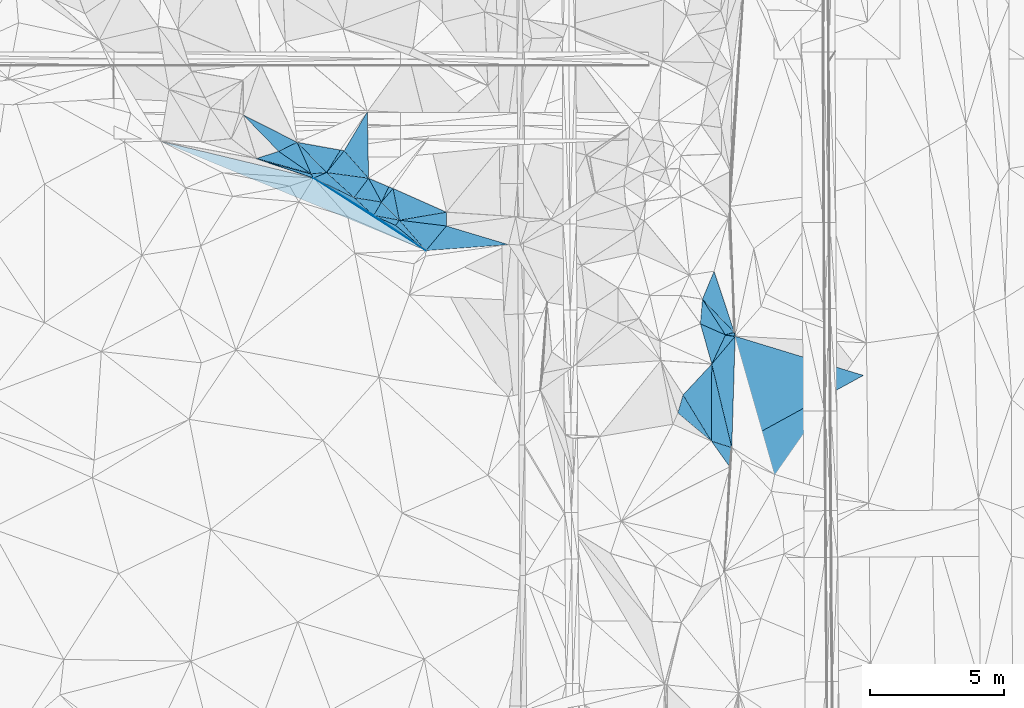
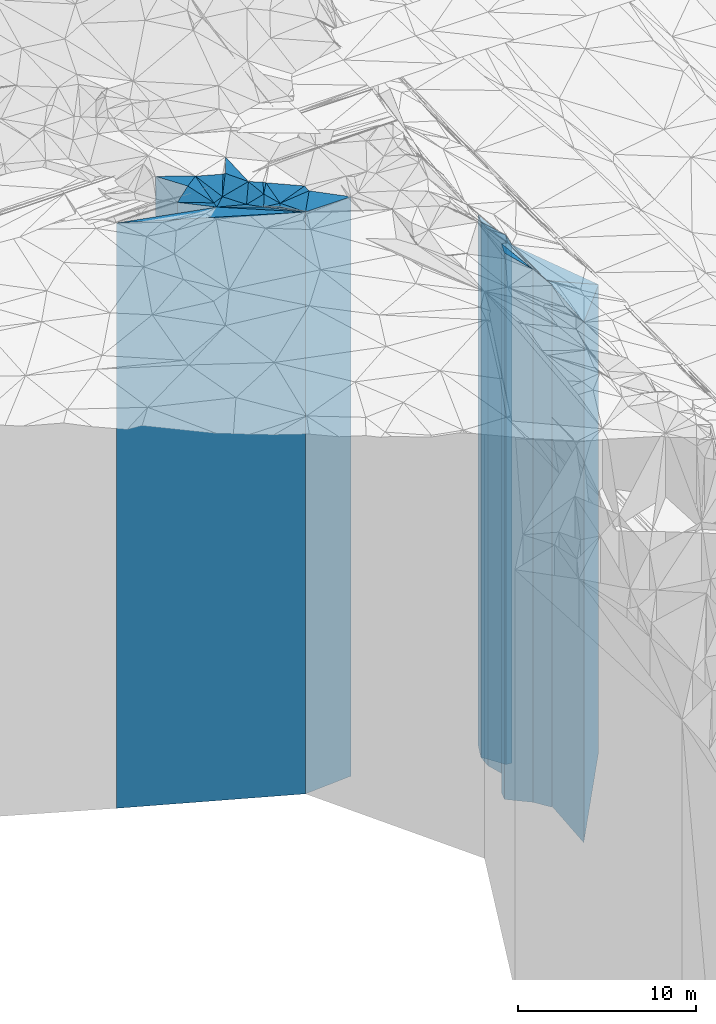
# One storey, part 208 of 275: 41 plates.
"""IFC2X3 building model written with IfcOpenShell, lengths in millimetres."""

from ifc_helpers import new_model, si_unit, frame, origin_with_axes, place, context, subcontext, project, spatial, faceted_brep, material, type_object, element, save


model = new_model("IFC2X3")

# Units and contexts
model_context = context("Model", 3, precision=1e-05, world=origin_with_axes())
body_context = subcontext(model_context, "Body", "Model", "MODEL_VIEW")
ifc_project = project(units=[si_unit("LENGTHUNIT", "METRE", prefix="MILLI"), si_unit("AREAUNIT", "SQUARE_METRE"), si_unit("VOLUMEUNIT", "CUBIC_METRE"), si_unit("MASSUNIT", "GRAM", prefix="KILO"), si_unit("TIMEUNIT", "SECOND"), si_unit("PLANEANGLEUNIT", "RADIAN"), si_unit("SOLIDANGLEUNIT", "STERADIAN"), si_unit("THERMODYNAMICTEMPERATUREUNIT", "DEGREE_CELSIUS"), si_unit("LUMINOUSINTENSITYUNIT", "LUMEN")], contexts=[model_context])

# Site, building, storey
site_placement = place(None, origin_with_axes())
site = spatial("IfcSite", under=ifc_project, at=site_placement, CompositionType="ELEMENT")
building_placement = place(site_placement, origin_with_axes())
building = spatial("IfcBuilding", under=site, at=building_placement, Name="Undefined", CompositionType="ELEMENT")
storey_placement = place(building_placement, origin_with_axes())
storey = spatial("IfcBuildingStorey", under=building, at=storey_placement, Name="Undefined", CompositionType="ELEMENT", Elevation=0.0)

# Plates
ifc_material = material()
plate_type_1 = type_object("IfcPlateType", PredefinedType="NOTDEFINED")
plate_1_placement = place(storey_placement, frame((-110294.740973737, 54065.2634649657, 27899.0), z_axis=(-0.804874960058612, 0.593444436043213, 0.0), x_axis=(0.593444436043218, 0.804874960058609, 0.0)))
element("IfcPlate", 1, at=plate_1_placement, inside=storey, type_object=plate_type_1, material=ifc_material, Name="00", context=body_context, shape_type="Brep", body=[
    faceted_brep([(-7.27595761418343e-12, -20071.0, 0.0), (-188.532791137703, -20151.0, 879.406250000015), (-188.532791137703, 20071.0, 879.406250000015), (-7.27595761418343e-12, 20071.0, 0.0), (241.867736816406, -20181.0, 1.16415321826935e-10), (241.867736816406, 20071.0, 1.16415321826935e-10)], [[[0, 1, 2, 3]], [[1, 4, 5, 2]], [[4, 0, 3, 5]], [[5, 3, 2]], [[4, 1, 0]]]),
])
plate_type_2 = type_object("IfcPlateType", PredefinedType="NOTDEFINED")
plate_2_placement = place(storey_placement, frame((-110294.740973737, 54065.2634649657, 27824.5), z_axis=(-0.411538900970538, -0.911392194934739, 0.0), x_axis=(-0.911392194934741, 0.411538900970533, 0.0)))
element("IfcPlate", 2, at=plate_2_placement, inside=storey, type_object=plate_type_2, material=ifc_material, Name="00", context=body_context, shape_type="Brep", body=[
    faceted_brep([(0.0, -20145.5, -1.59161572810262e-11), (-1425.35705566406, -19996.5, 394.501281738265), (-1425.35705566406, 19996.5, 394.501281738265), (0.0, 19996.5, -1.59161572810262e-11), (899.388671875, -20225.5, -2.32967067859136e-09), (899.388671875, 19996.5, -2.32967067859136e-09)], [[[0, 1, 2, 3]], [[1, 4, 5, 2]], [[4, 0, 3, 5]], [[5, 3, 2]], [[4, 1, 0]]]),
])
plate_type_3 = type_object("IfcPlateType", PredefinedType="NOTDEFINED")
plate_3_placement = place(storey_placement, frame((-110390.601709133, 55444.2887437077, 27954.0), z_axis=(0.762095998100835, -0.647464045085665, 0.0), x_axis=(-0.647464045085671, -0.76209599810083, 0.0)))
element("IfcPlate", 3, at=plate_3_placement, inside=storey, type_object=plate_type_3, material=ifc_material, Name="00", context=body_context, shape_type="Brep", body=[
    faceted_brep([(-7.27595761418343e-12, -20896.0, 0.0), (747.589721679695, -20126.0, 949.267883300781), (747.589721679695, 20126.0, 949.267883300781), (-7.27595761418343e-12, 20126.0, 0.0), (666.408264160164, -20576.0, 3.84170562028885e-09), (666.408264160164, 20126.0, 3.84170562028885e-09)], [[[0, 1, 2, 3]], [[1, 4, 5, 2]], [[4, 0, 3, 5]], [[5, 3, 2]], [[4, 1, 0]]]),
])
plate_type_4 = type_object("IfcPlateType", PredefinedType="NOTDEFINED")
plate_4_placement = place(storey_placement, frame((-110294.740973737, 54065.2634649657, 27824.5), z_axis=(0.639737251043329, 0.768593683052057, 0.0), x_axis=(0.768593683052057, -0.639737251043329, 0.0)))
element("IfcPlate", 4, at=plate_4_placement, inside=storey, type_object=plate_type_4, material=ifc_material, Name="00", context=body_context, shape_type="Brep", body=[
    faceted_brep([(0.0, -20145.5, -1.59161572810262e-11), (-14.2196102142334, -20255.5, 241.449386596683), (-14.2196102142334, 19996.5, 241.449386596683), (0.0, 19996.5, -1.59161572810262e-11), (1478.94348144533, -19996.5, 5.68616087548435e-09), (1478.94348144533, 19996.5, 5.68616087548435e-09)], [[[0, 1, 2, 3]], [[1, 4, 5, 2]], [[4, 0, 3, 5]], [[5, 3, 2]], [[4, 1, 0]]]),
])
plate_type_5 = type_object("IfcPlateType", PredefinedType="NOTDEFINED")
plate_5_placement = place(storey_placement, frame((-110822.07711198, 54936.4216580074, 27939.0), z_axis=(-0.162954212081307, -0.986633632492305, 0.0), x_axis=(-0.986633632492305, 0.162954212081309, 0.0)))
element("IfcPlate", 5, at=plate_5_placement, inside=storey, type_object=plate_type_5, material=ifc_material, Name="00", context=body_context, shape_type="Brep", body=[
    faceted_brep([(0.0, -20591.0, 0.0), (206.807800292969, -20111.0, 541.969116210938), (206.807800292969, 20111.0, 541.969116210938), (0.0, 20111.0, 0.0), (1040.09619140625, -20141.0, -8.29459168016911e-10), (1040.09619140625, 20111.0, -8.29459168016911e-10)], [[[0, 1, 2, 3]], [[1, 4, 5, 2]], [[4, 0, 3, 5]], [[5, 3, 2]], [[4, 1, 0]]]),
])
plate_type_6 = type_object("IfcPlateType", PredefinedType="NOTDEFINED")
plate_6_placement = place(storey_placement, frame((-111114.436798136, 54435.3968942372, 27906.0), z_axis=(-0.674538327096492, -0.7382398291056, 0.0), x_axis=(-0.738239829105603, 0.674538327096489, 0.0)))
element("IfcPlate", 6, at=plate_6_placement, inside=storey, type_object=plate_type_6, material=ifc_material, Name="00", context=body_context, shape_type="Brep", body=[
    faceted_brep([(2.91038304567337e-11, -20144.0, -1.45519152283669e-11), (2605.13696289063, -20078.0, 486.845397949219), (2605.13696289063, 20078.0, 486.845397949219), (2.91038304567337e-11, 20078.0, -1.45519152283669e-11), (994.032165527358, -20174.0, 9.60426405072212e-10), (994.032165527358, 20078.0, 9.60426405072212e-10)], [[[0, 1, 2, 3]], [[1, 4, 5, 2]], [[4, 0, 3, 5]], [[5, 3, 2]], [[4, 1, 0]]]),
])
plate_type_7 = type_object("IfcPlateType", PredefinedType="NOTDEFINED")
plate_7_placement = place(storey_placement, frame((-110151.205913781, 54259.9367465515, 27939.0), z_axis=(-0.710046754280329, -0.704154533278008, 0.0), x_axis=(-0.704154533278, 0.710046754280337, 0.0)))
element("IfcPlate", 7, at=plate_7_placement, inside=storey, type_object=plate_type_7, material=ifc_material, Name="00", context=body_context, shape_type="Brep", body=[
    faceted_brep([(0.0, -20141.0, -7.27595761418343e-12), (802.848327636719, -20111.0, 560.387878417961), (802.848327636719, 20111.0, 560.387878417961), (0.0, 20111.0, 0.0), (952.73291015625, -20591.0, -1.09139364212751e-09), (952.73291015625, 20111.0, -1.09139364212751e-09)], [[[0, 1, 2, 3]], [[1, 4, 5, 2]], [[4, 0, 3, 5]], [[5, 3, 2]], [[4, 1, 0]]]),
])
plate_type_8 = type_object("IfcPlateType", PredefinedType="NOTDEFINED")
plate_8_placement = place(storey_placement, frame((-112874.021187046, 56040.9693087682, 27906.0), z_axis=(0.388926703048877, -0.921268701115766, 0.0), x_axis=(-0.921268701115766, -0.388926703048877, 0.0)))
element("IfcPlate", 8, at=plate_8_placement, inside=storey, type_object=plate_type_8, material=ifc_material, Name="00", context=body_context, shape_type="Brep", body=[
    faceted_brep([(1.45519152283669e-11, -20494.0, -1.45519152283669e-11), (-581.321960449204, -20174.0, 1260.3828125), (-581.321960449204, 20078.0, 1260.3828125), (2.91038304567337e-11, 20078.0, -1.45519152283669e-11), (534.075866699233, -20078.0, 4.65661287307739e-10), (534.075866699233, 20078.0, 4.65661287307739e-10)], [[[0, 1, 2, 3]], [[1, 4, 5, 2]], [[4, 0, 3, 5]], [[5, 3, 2]], [[4, 1, 0]]]),
])
plate_type_9 = type_object("IfcPlateType", PredefinedType="NOTDEFINED")
plate_9_placement = place(storey_placement, frame((-110548.879326198, 55505.5112553854, 28179.0), z_axis=(-0.392684399118446, -0.919673291277389, 0.0), x_axis=(-0.91967329127739, 0.392684399118444, 0.0)))
element("IfcPlate", 9, at=plate_9_placement, inside=storey, type_object=plate_type_9, material=ifc_material, Name="00", context=body_context, shape_type="Brep", body=[
    faceted_brep([(-1.45519152283669e-11, -20731.0, -1.36424205265939e-11), (27.7800998687744, -20351.0, 630.656982421861), (27.7800998687744, 20351.0, 630.656982421861), (-1.45519152283669e-11, 20351.0, -1.36424205265939e-11), (820.731384277329, -20841.0, 1.99452188098803e-09), (820.731384277329, 20351.0, 1.99452188098803e-09)], [[[0, 1, 2, 3]], [[1, 4, 5, 2]], [[4, 0, 3, 5]], [[5, 3, 2]], [[4, 1, 0]]]),
])
plate_type_10 = type_object("IfcPlateType", PredefinedType="NOTDEFINED")
plate_10_placement = place(storey_placement, frame((-111303.684056734, 55827.7996646714, 27954.0), z_axis=(-0.134513978030471, -0.990911696224451, 0.0), x_axis=(-0.990911696224451, 0.134513978030468, 0.0)))
element("IfcPlate", 10, at=plate_10_placement, inside=storey, type_object=plate_type_10, material=ifc_material, Name="00", context=body_context, shape_type="Brep", body=[
    faceted_brep([(0.0, -21066.0, -7.27595761418343e-12), (442.533233642578, -20126.0, 788.58374023436), (442.533233642578, 20126.0, 788.58374023436), (-7.27595761418343e-12, 20126.0, 0.0), (1584.73974609375, -20446.0, 4.19822754338384e-09), (1584.73974609375, 20126.0, 4.19822754338384e-09)], [[[0, 1, 2, 3]], [[1, 4, 5, 2]], [[4, 0, 3, 5]], [[5, 3, 2]], [[4, 1, 0]]]),
])
plate_type_11 = type_object("IfcPlateType", PredefinedType="NOTDEFINED")
plate_11_placement = place(storey_placement, frame((-111351.75100567, 58310.4171479781, 28424.0), z_axis=(0.859259778895066, -0.511539472937527, 0.0), x_axis=(-0.511539472937527, -0.859259778895066, 0.0)))
element("IfcPlate", 11, at=plate_11_placement, inside=storey, type_object=plate_type_11, material=ifc_material, Name="00", context=body_context, shape_type="Brep", body=[
    faceted_brep([(-5.45696821063757e-12, -20786.0, 0.0), (2108.62524414063, -20596.0, 1311.2587890625), (2108.62524414063, 20596.0, 1311.2587890625), (-5.45696821063757e-12, 20596.0, 0.0), (1692.57202148438, -20856.0, 6.12635631114244e-09), (1692.57202148438, 20596.0, 6.12635631114244e-09)], [[[0, 1, 2, 3]], [[1, 4, 5, 2]], [[4, 0, 3, 5]], [[5, 3, 2]], [[4, 1, 0]]]),
])
plate_type_12 = type_object("IfcPlateType", PredefinedType="NOTDEFINED")
plate_12_placement = place(storey_placement, frame((-111303.684056734, 55827.7996646714, 28114.0), z_axis=(-0.747453769865745, -0.664313827880683, 0.0), x_axis=(-0.66431382788068, 0.747453769865748, 0.0)))
element("IfcPlate", 12, at=plate_12_placement, inside=storey, type_object=plate_type_12, material=ifc_material, Name="00", context=body_context, shape_type="Brep", body=[
    faceted_brep([(0.0, -20906.0, 2.91038304567337e-11), (1202.53112792969, -20286.0, 1032.14282226563), (1202.53112792969, 20286.0, 1032.14282226563), (0.0, 20286.0, 2.91038304567337e-11), (1375.681640625, -21166.0, 9.27684595808387e-09), (1375.681640625, 20286.0, 9.27684595808387e-09)], [[[0, 1, 2, 3]], [[1, 4, 5, 2]], [[4, 0, 3, 5]], [[5, 3, 2]], [[4, 1, 0]]]),
])
plate_type_13 = type_object("IfcPlateType", PredefinedType="NOTDEFINED")
plate_13_placement = place(storey_placement, frame((-115991.097209185, 58194.3705886519, 28554.0), z_axis=(0.71694222823, 0.697132585223645, 0.0), x_axis=(0.697132585223645, -0.71694222823, 0.0)))
element("IfcPlate", 13, at=plate_13_placement, inside=storey, type_object=plate_type_13, material=ifc_material, Name="00", context=body_context, shape_type="Brep", body=[
    faceted_brep([(0.0, -21036.0, 0.0), (2137.98803710938, -20956.0, 732.398376464836), (2137.98803710938, 20726.0, 732.398376464836), (0.0, 20726.0, 0.0), (1898.42041015626, -20726.0, -7.53061613067985e-09), (1898.42041015626, 20726.0, -7.53061613067985e-09)], [[[0, 1, 2, 3]], [[1, 4, 5, 2]], [[4, 0, 3, 5]], [[5, 3, 2]], [[4, 1, 0]]]),
])
plate_type_14 = type_object("IfcPlateType", PredefinedType="NOTDEFINED")
plate_14_placement = place(storey_placement, frame((-112874.021187046, 56040.9693087682, 28114.0), z_axis=(-0.778822297908559, 0.627244631926358, 0.0), x_axis=(0.627244631926356, 0.77882229790856, 0.0)))
element("IfcPlate", 14, at=plate_14_placement, inside=storey, type_object=plate_type_14, material=ifc_material, Name="00", context=body_context, shape_type="Brep", body=[
    faceted_brep([(-1.09139364212751e-11, -20286.0, -1.45519152283669e-11), (976.622741699201, -21146.0, 126.126800537109), (976.622741699201, 20286.0, 126.126800537109), (0.0, 20286.0, 2.91038304567337e-11), (1046.56579589843, -21166.0, -3.37604433298111e-09), (1046.56579589843, 20286.0, -3.37604433298111e-09)], [[[0, 1, 2, 3]], [[1, 4, 5, 2]], [[4, 0, 3, 5]], [[5, 3, 2]], [[4, 1, 0]]]),
])
plate_type_15 = type_object("IfcPlateType", PredefinedType="NOTDEFINED")
plate_15_placement = place(storey_placement, frame((-113975.54879864, 57172.1354861696, 28019.0), z_axis=(0.914583869967225, 0.404396271985505, 0.0), x_axis=(0.404396271985505, -0.914583869967225, 0.0)))
element("IfcPlate", 15, at=plate_15_placement, inside=storey, type_object=plate_type_15, material=ifc_material, Name="00", context=body_context, shape_type="Brep", body=[
    faceted_brep([(0.0, -21491.0, 0.0), (1480.0, -20381.0, 549.999999999985), (1480.0, 20191.0, 549.999999999985), (0.0, 20191.0, 0.0), (1290.0, -20191.0, -2.79396772384644e-09), (1290.0, 20191.0, -2.79396772384644e-09)], [[[0, 1, 2, 3]], [[1, 4, 5, 2]], [[4, 0, 3, 5]], [[5, 3, 2]], [[4, 1, 0]]]),
])
plate_type_16 = type_object("IfcPlateType", PredefinedType="NOTDEFINED")
plate_16_placement = place(storey_placement, frame((-110390.601709133, 55444.2887437077, 28179.0), z_axis=(-0.360757109901238, -0.932659802744659, 0.0), x_axis=(-0.932659802744667, 0.360757109901216, 0.0)))
element("IfcPlate", 16, at=plate_16_placement, inside=storey, type_object=plate_type_16, material=ifc_material, Name="00", context=body_context, shape_type="Brep", body=[
    faceted_brep([(1.45519152283669e-11, -20671.0, 5.45696821063757e-12), (219.203109741211, -20351.0, 629.325012207044), (219.203109741211, 20351.0, 629.325012207044), (-1.45519152283669e-11, 20351.0, -1.36424205265939e-11), (169.705627441421, -20731.0, 6.60293153487146e-10), (169.705627441421, 20351.0, 6.60293153487146e-10)], [[[0, 1, 2, 3]], [[1, 4, 5, 2]], [[4, 0, 3, 5]], [[5, 3, 2]], [[4, 1, 0]]]),
])
plate_type_17 = type_object("IfcPlateType", PredefinedType="NOTDEFINED")
plate_17_placement = place(storey_placement, frame((-98381.8933212133, 52345.9145161625, 25714.0), z_axis=(0.923352372603806, -0.383953637835251, 0.0), x_axis=(-0.383953637835247, -0.923352372603807, 0.0)))
element("IfcPlate", 17, at=plate_17_placement, inside=storey, type_object=plate_type_17, material=ifc_material, Name="00", context=body_context, shape_type="Brep", body=[
    faceted_brep([(-1.45519152283669e-11, -18616.0, -1.45519152283669e-11), (1820.76135253905, -17886.0, 1580.42016601563), (1820.76135253905, 17886.0, 1580.42016601563), (-7.27595761418343e-12, 17886.0, -1.45519152283669e-11), (1131.72436523438, -18906.0, -5.32600097358227e-09), (1131.72436523438, 17886.0, -5.32600097358227e-09)], [[[0, 1, 2, 3]], [[1, 4, 5, 2]], [[4, 0, 3, 5]], [[5, 3, 2]], [[4, 1, 0]]]),
])
plate_type_18 = type_object("IfcPlateType", PredefinedType="NOTDEFINED")
plate_18_placement = place(storey_placement, frame((-97952.8748867231, 49966.1365469252, 25714.0), z_axis=(-0.267026689978366, 0.963689133921929, 0.0), x_axis=(0.963689133921928, 0.26702668997837, 0.0)))
element("IfcPlate", 18, at=plate_18_placement, inside=storey, type_object=plate_type_18, material=ifc_material, Name="00", context=body_context, shape_type="Brep", body=[
    faceted_brep([(0.0, -18516.0, 0.0), (-475.765350341811, -18906.0, 1516.92028808594), (-475.765350341811, 17886.0, 1516.92028808594), (-7.27595761418343e-12, 17886.0, -1.45519152283669e-11), (343.656799316406, -17886.0, 2.91038304567337e-10), (343.656799316406, 17886.0, 2.91038304567337e-10)], [[[0, 1, 2, 3]], [[1, 4, 5, 2]], [[4, 0, 3, 5]], [[5, 3, 2]], [[4, 1, 0]]]),
])
plate_type_19 = type_object("IfcPlateType", PredefinedType="NOTDEFINED")
plate_19_placement = place(storey_placement, frame((-98816.4230019084, 51300.9341543399, 26029.0), z_axis=(0.996697259231024, -0.0812069790188259, 0.0), x_axis=(-0.0812069790188177, -0.996697259231025, 0.0)))
element("IfcPlate", 19, at=plate_19_placement, inside=storey, type_object=plate_type_19, material=ifc_material, Name="00", context=body_context, shape_type="Brep", body=[
    faceted_brep([(0.0, -18591.0, 1.45519152283669e-11), (1260.26293945312, -18201.0, 969.090942382813), (1260.26293945312, 18201.0, 969.090942382813), (0.0, 18201.0, 1.45519152283669e-11), (921.791748046875, -18691.0, 4.65661287307739e-10), (921.791748046875, 18201.0, 4.65661287307739e-10)], [[[0, 1, 2, 3]], [[1, 4, 5, 2]], [[4, 0, 3, 5]], [[5, 3, 2]], [[4, 1, 0]]]),
])
plate_type_20 = type_object("IfcPlateType", PredefinedType="NOTDEFINED")
plate_20_placement = place(storey_placement, frame((-97621.6965573815, 50057.9020860697, 25649.5), z_axis=(0.267026689978366, -0.963689133921929, 0.0), x_axis=(-0.96368913392193, -0.267026689978361, 0.0)))
element("IfcPlate", 20, at=plate_20_placement, inside=storey, type_object=plate_type_20, material=ifc_material, Name="00", context=body_context, shape_type="Brep", body=[
    faceted_brep([(1.45519152283669e-11, -17950.5, 0.0), (9.31161499024893, -17821.5, 142.875091552734), (9.31161499024893, 17821.5, 142.875091552734), (1.45519152283669e-11, 17821.5, 0.0), (343.656799316421, -18580.5, 2.91038304567337e-10), (343.656799316421, 17821.5, 2.91038304567337e-10)], [[[0, 1, 2, 3]], [[1, 4, 5, 2]], [[4, 0, 3, 5]], [[5, 3, 2]], [[4, 1, 0]]]),
])
plate_type_21 = type_object("IfcPlateType", PredefinedType="NOTDEFINED")
plate_21_placement = place(storey_placement, frame((-97952.8748867231, 49966.1365469252, 26029.0), z_axis=(-0.405310041011432, -0.914179288025774, 0.0), x_axis=(-0.914179288025777, 0.405310041011426, 0.0)))
element("IfcPlate", 21, at=plate_21_placement, inside=storey, type_object=plate_type_21, material=ifc_material, Name="00", context=body_context, shape_type="Brep", body=[
    faceted_brep([(1.45519152283669e-11, -18201.0, 5.45696821063757e-12), (26.7900924682763, -18491.0, 1204.77478027344), (26.7900924682763, 18201.0, 1204.77478027344), (0.0, 18201.0, 1.45519152283669e-11), (1026.4989013672, -18691.0, -1.52977008838207e-09), (1026.4989013672, 18201.0, -1.52977008838207e-09)], [[[0, 1, 2, 3]], [[1, 4, 5, 2]], [[4, 0, 3, 5]], [[5, 3, 2]], [[4, 1, 0]]]),
])
plate_type_22 = type_object("IfcPlateType", PredefinedType="NOTDEFINED")
plate_22_placement = place(storey_placement, frame((-97952.8748867231, 49966.1365469252, 25649.5), z_axis=(0.904942867649929, -0.425533084835389, 0.0), x_axis=(-0.425533084835388, -0.90494286764993, 0.0)))
element("IfcPlate", 22, at=plate_22_placement, inside=storey, type_object=plate_type_22, material=ifc_material, Name="00", context=body_context, shape_type="Brep", body=[
    faceted_brep([(7.27595761418343e-12, -18580.5, -1.45519152283669e-11), (-109.536964416489, -17821.5, 346.701110839829), (-109.536964416489, 17821.5, 346.701110839829), (1.45519152283669e-11, 17821.5, 0.0), (1205.07263183595, -18870.5, 3.34694050252438e-09), (1205.07263183595, 17821.5, 3.34694050252438e-09)], [[[0, 1, 2, 3]], [[1, 4, 5, 2]], [[4, 0, 3, 5]], [[5, 3, 2]], [[4, 1, 0]]]),
])
plate_type_23 = type_object("IfcPlateType", PredefinedType="NOTDEFINED")
plate_23_placement = place(storey_placement, frame((-108393.037823814, 54042.34775919, 27954.0), z_axis=(-0.999992480215602, 0.00387808100083869, 0.0), x_axis=(0.00387808100083843, 0.999992480215602, 0.0)))
element("IfcPlate", 23, at=plate_23_placement, inside=storey, type_object=plate_type_23, material=ifc_material, Name="00", context=body_context, shape_type="Brep", body=[
    faceted_brep([(2.91038304567337e-11, -20496.0, 2.91038304567337e-11), (210.769027709968, -20126.0, 1758.99865722659), (210.769027709968, 20126.0, 1758.99865722659), (-7.27595761418343e-12, 20126.0, 0.0), (514.781494140632, -20516.0, -6.83940015733242e-10), (514.781494140632, 20126.0, -6.83940015733242e-10)], [[[0, 1, 2, 3]], [[1, 4, 5, 2]], [[4, 0, 3, 5]], [[5, 3, 2]], [[4, 1, 0]]]),
])
plate_type_24 = type_object("IfcPlateType", PredefinedType="NOTDEFINED")
plate_24_placement = place(storey_placement, frame((-110151.205913781, 54259.9367465515, 27954.0), z_axis=(-0.166485055964927, 0.986043977792246, 0.0), x_axis=(0.986043977792247, 0.166485055964922, 0.0)))
element("IfcPlate", 24, at=plate_24_placement, inside=storey, type_object=plate_type_24, material=ifc_material, Name="00", context=body_context, shape_type="Brep", body=[
    faceted_brep([(0.0, -20126.0, 0.0), (-38.8778724670265, -20896.0, 1207.67895507813), (-38.8778724670265, 20126.0, 1207.67895507813), (-7.27595761418343e-12, 20126.0, 0.0), (1785.07702636722, -20516.0, 5.5297277867794e-10), (1785.07702636722, 20126.0, 5.5297277867794e-10)], [[[0, 1, 2, 3]], [[1, 4, 5, 2]], [[4, 0, 3, 5]], [[5, 3, 2]], [[4, 1, 0]]]),
])
plate_type_25 = type_object("IfcPlateType", PredefinedType="NOTDEFINED")
plate_25_placement = place(storey_placement, frame((-113975.54879864, 57172.1354861696, 28019.0), z_axis=(0.439695815882969, -0.898146752760934, 0.0), x_axis=(-0.898146752760938, -0.439695815882961, 0.0)))
element("IfcPlate", 25, at=plate_25_placement, inside=storey, type_object=plate_type_25, material=ifc_material, Name="00", context=body_context, shape_type="Brep", body=[
    faceted_brep([(0.0, -21491.0, 0.0), (50.2216377258446, -20191.0, 1289.02197265624), (50.2216377258446, 20191.0, 1289.02197265624), (0.0, 20191.0, 0.0), (770.584167480469, -21261.0, -3.36149241775274e-09), (770.584167480469, 20191.0, -3.36149241775274e-09)], [[[0, 1, 2, 3]], [[1, 4, 5, 2]], [[4, 0, 3, 5]], [[5, 3, 2]], [[4, 1, 0]]]),
])
plate_type_26 = type_object("IfcPlateType", PredefinedType="NOTDEFINED")
plate_26_placement = place(storey_placement, frame((-112874.021187046, 56040.9693087682, 28114.0), z_axis=(-0.852746429709146, 0.522325115821846, 0.0), x_axis=(0.52232511582185, 0.852746429709144, 0.0)))
element("IfcPlate", 26, at=plate_26_placement, inside=storey, type_object=plate_type_26, material=ifc_material, Name="00", context=body_context, shape_type="Brep", body=[
    faceted_brep([(-1.09139364212751e-11, -20286.0, -1.45519152283669e-11), (389.242370605476, -21396.0, 1530.16027832033), (389.242370605476, 20286.0, 1530.16027832033), (0.0, 20286.0, 2.91038304567337e-11), (984.733459472656, -21146.0, -2.99769453704357e-09), (984.733459472656, 20286.0, -2.99769453704357e-09)], [[[0, 1, 2, 3]], [[1, 4, 5, 2]], [[4, 0, 3, 5]], [[5, 3, 2]], [[4, 1, 0]]]),
])
plate_type_27 = type_object("IfcPlateType", PredefinedType="NOTDEFINED")
plate_27_placement = place(storey_placement, frame((-115499.730121397, 56563.8006315393, 27906.0), z_axis=(0.323927415925186, 0.946081935781479, 0.0), x_axis=(0.946081935781482, -0.32392741592518, 0.0)))
element("IfcPlate", 27, at=plate_27_placement, inside=storey, type_object=plate_type_27, material=ifc_material, Name="00", context=body_context, shape_type="Brep", body=[
    faceted_brep([(-1.45519152283669e-11, -20704.0, 1.81898940354586e-12), (2120.66162109374, -20304.0, 122.042388916025), (2120.66162109374, 20078.0, 122.042388916025), (2.91038304567337e-11, 20078.0, -1.45519152283669e-11), (2255.28198242186, -20078.0, 1.02827470982447e-08), (2255.28198242186, 20078.0, 1.02827470982447e-08)], [[[0, 1, 2, 3]], [[1, 4, 5, 2]], [[4, 0, 3, 5]], [[5, 3, 2]], [[4, 1, 0]]]),
])
plate_type_28 = type_object("IfcPlateType", PredefinedType="NOTDEFINED")
plate_28_placement = place(storey_placement, frame((-111848.270953969, 55105.9097067414, 27954.0), z_axis=(0.162954212081307, 0.986633632492305, 0.0), x_axis=(0.986633632492304, -0.162954212081311, 0.0)))
element("IfcPlate", 28, at=plate_28_placement, inside=storey, type_object=plate_type_28, material=ifc_material, Name="00", context=body_context, shape_type="Brep", body=[
    faceted_brep([(0.0, -20126.0, 0.0), (419.672729492188, -21066.0, 800.983642578125), (419.672729492188, 20126.0, 800.983642578125), (-7.27595761418343e-12, 20126.0, 0.0), (1040.09619140626, -20576.0, -8.36735125631094e-10), (1040.09619140626, 20126.0, -8.36735125631094e-10)], [[[0, 1, 2, 3]], [[1, 4, 5, 2]], [[4, 0, 3, 5]], [[5, 3, 2]], [[4, 1, 0]]]),
])
plate_type_29 = type_object("IfcPlateType", PredefinedType="NOTDEFINED")
plate_29_placement = place(storey_placement, frame((-108393.037823814, 54042.34775919, 27740.0), z_axis=(0.770003888661502, -0.638039192719511, 0.0), x_axis=(-0.638039192719509, -0.770003888661504, 0.0)))
element("IfcPlate", 29, at=plate_29_placement, inside=storey, type_object=plate_type_29, material=ifc_material, Name="00", context=body_context, shape_type="Brep", body=[
    faceted_brep([(0.0, -20710.0, 3.63797880709171e-12), (-946.570922851563, -19912.0, 2236.35180664063), (-946.570922851563, 19912.0, 2236.35180664063), (-7.27595761418343e-12, 19912.0, -2.91038304567337e-11), (1198.9803466797, -20081.0, 1.83354131877422e-09), (1198.9803466797, 19912.0, 1.83354131877422e-09)], [[[0, 1, 2, 3]], [[1, 4, 5, 2]], [[4, 0, 3, 5]], [[5, 3, 2]], [[4, 1, 0]]]),
])
plate_type_30 = type_object("IfcPlateType", PredefinedType="NOTDEFINED")
plate_30_placement = place(storey_placement, frame((-113453.877607181, 55992.3222941762, 28019.0), z_axis=(-0.569525361298801, -0.821973760431238, 0.0), x_axis=(-0.82197376043124, 0.569525361298798, 0.0)))
element("IfcPlate", 30, at=plate_30_placement, inside=storey, type_object=plate_type_30, material=ifc_material, Name="00", context=body_context, shape_type="Brep", body=[
    faceted_brep([(0.0, -20191.0, -1.45519152283669e-11), (2007.10852050784, -20591.0, 695.424682617198), (2007.10852050784, 20191.0, 695.424682617198), (0.0, 20191.0, 0.0), (1476.65161132814, -21261.0, 5.32236299477518e-09), (1476.65161132814, 20191.0, 5.32236299477518e-09)], [[[0, 1, 2, 3]], [[1, 4, 5, 2]], [[4, 0, 3, 5]], [[5, 3, 2]], [[4, 1, 0]]]),
])
plate_type_31 = type_object("IfcPlateType", PredefinedType="NOTDEFINED")
plate_31_placement = place(storey_placement, frame((-98481.3199227514, 45993.0715029198, 25695.5), z_axis=(0.299826167899354, 0.953993851679762, 0.0), x_axis=(0.953993851679761, -0.299826167899358, 0.0)))
element("IfcPlate", 31, at=plate_31_placement, inside=storey, type_object=plate_type_31, material=ifc_material, Name="00", context=body_context, shape_type="Brep", body=[
    faceted_brep([(-1.45519152283669e-11, -18754.5, 3.63797880709171e-12), (-849.334960937515, -18824.5, 2754.61987304688), (-849.334960937515, 17867.5, 2754.61987304688), (-1.45519152283669e-11, 17867.5, 3.63797880709171e-12), (799.990600585923, -17867.5, 1.01499608717859e-09), (799.990600585923, 17867.5, 1.01499608717859e-09)], [[[0, 1, 2, 3]], [[1, 4, 5, 2]], [[4, 0, 3, 5]], [[5, 3, 2]], [[4, 1, 0]]]),
])
plate_type_32 = type_object("IfcPlateType", PredefinedType="NOTDEFINED")
plate_32_placement = place(storey_placement, frame((-98465.6731529722, 48875.6146818845, 25649.5), z_axis=(0.972516987246173, 0.23283193405894, 0.0), x_axis=(0.232831934058936, -0.972516987246174, 0.0)))
element("IfcPlate", 32, at=plate_32_placement, inside=storey, type_object=plate_type_32, material=ifc_material, Name="00", context=body_context, shape_type="Brep", body=[
    faceted_brep([(0.0, -18870.5, 0.0), (-810.175109863267, -17821.5, 1091.79504394531), (-810.175109863267, 17821.5, 1091.79504394531), (1.45519152283669e-11, 17821.5, 0.0), (3210.63940429688, -17913.5, -4.13274392485619e-09), (3210.63940429688, 17821.5, -4.13274392485619e-09)], [[[0, 1, 2, 3]], [[1, 4, 5, 2]], [[4, 0, 3, 5]], [[5, 3, 2]], [[4, 1, 0]]]),
])
plate_type_33 = type_object("IfcPlateType", PredefinedType="NOTDEFINED")
plate_33_placement = place(storey_placement, frame((-97792.7201179677, 45029.2093193832, 25695.5), z_axis=(-0.994735388204004, 0.10247686302102, 0.0), x_axis=(0.102476863021017, 0.994735388204005, 0.0)))
element("IfcPlate", 33, at=plate_33_placement, inside=storey, type_object=plate_type_33, material=ifc_material, Name="00", context=body_context, shape_type="Brep", body=[
    faceted_brep([(7.27595761418343e-12, -18004.5, 1.45519152283669e-11), (888.222290039063, -18754.5, 783.748168945327), (888.222290039063, 17867.5, 783.748168945327), (-1.45519152283669e-11, 17867.5, 3.63797880709171e-12), (727.835815429695, -17867.5, -8.14907252788544e-10), (727.835815429695, 17867.5, -8.14907252788544e-10)], [[[0, 1, 2, 3]], [[1, 4, 5, 2]], [[4, 0, 3, 5]], [[5, 3, 2]], [[4, 1, 0]]]),
])
plate_type_34 = type_object("IfcPlateType", PredefinedType="NOTDEFINED")
plate_34_placement = place(storey_placement, frame((-99541.0940752094, 47722.198087581, 26139.0), z_axis=(0.961490975586377, -0.274836503881774, 0.0), x_axis=(-0.274836503881765, -0.96149097558638, 0.0)))
element("IfcPlate", 34, at=plate_34_placement, inside=storey, type_object=plate_type_34, material=ifc_material, Name="00", context=body_context, shape_type="Brep", body=[
    faceted_brep([(3.63797880709171e-12, -19421.0, 0.0), (1371.27502441406, -18311.0, 1494.1904296875), (1371.27502441406, 18311.0, 1494.1904296875), (7.27595761418343e-12, 18311.0, 1.45519152283669e-11), (702.922485351563, -19251.0, -2.4156179279089e-09), (702.922485351563, 18311.0, -2.4156179279089e-09)], [[[0, 1, 2, 3]], [[1, 4, 5, 2]], [[4, 0, 3, 5]], [[5, 3, 2]], [[4, 1, 0]]]),
])
plate_type_35 = type_object("IfcPlateType", PredefinedType="NOTDEFINED")
plate_35_placement = place(storey_placement, frame((-110151.205913781, 54259.9367465515, 27824.5), z_axis=(0.754224290865757, 0.656616873883124, 0.0), x_axis=(0.656616873883129, -0.754224290865752, 0.0)))
element("IfcPlate", 35, at=plate_35_placement, inside=storey, type_object=plate_type_35, material=ifc_material, Name="00", context=body_context, shape_type="Brep", body=[
    faceted_brep([(0.0, -20255.5, -2.18278728425503e-11), (1318.55371093749, -20625.5, 1183.18041992186), (1318.55371093749, 19996.5, 1183.18041992186), (0.0, 19996.5, -1.59161572810262e-11), (1512.55871582033, -19996.5, -6.70843292027712e-09), (1512.55871582033, 19996.5, -6.70843292027712e-09)], [[[0, 1, 2, 3]], [[1, 4, 5, 2]], [[4, 0, 3, 5]], [[5, 3, 2]], [[4, 1, 0]]]),
])
plate_type_36 = type_object("IfcPlateType", PredefinedType="NOTDEFINED")
plate_36_placement = place(storey_placement, frame((-98465.6731529722, 48875.6146818845, 26139.0), z_axis=(0.731403499964048, -0.681944953966477, 0.0), x_axis=(-0.681944953966479, -0.731403499964046, 0.0)))
element("IfcPlate", 36, at=plate_36_placement, inside=storey, type_object=plate_type_36, material=ifc_material, Name="00", context=body_context, shape_type="Brep", body=[
    faceted_brep([(0.0, -18381.0, -1.45519152283669e-11), (2118.97241210939, -18311.0, 1954.29162597655), (2118.97241210939, 18311.0, 1954.29162597655), (7.27595761418343e-12, 18311.0, 1.45519152283669e-11), (1576.99084472657, -19421.0, -4.99130692332983e-09), (1576.99084472657, 18311.0, -4.99130692332983e-09)], [[[0, 1, 2, 3]], [[1, 4, 5, 2]], [[4, 0, 3, 5]], [[5, 3, 2]], [[4, 1, 0]]]),
])
plate_type_37 = type_object("IfcPlateType", PredefinedType="NOTDEFINED")
plate_37_placement = place(storey_placement, frame((-92793.4238682116, 48453.3860097972, 23881.5), z_axis=(-0.291845269942582, -0.956465544811804, 0.0), x_axis=(-0.956465544811806, 0.291845269942577, 0.0)))
element("IfcPlate", 37, at=plate_37_placement, inside=storey, type_object=plate_type_37, material=ifc_material, Name="00", context=body_context, shape_type="Brep", body=[
    faceted_brep([(1.45519152283669e-11, -16053.5, -7.27595761418343e-12), (3922.28271484374, -19681.5, 4019.87548828125), (3922.28271484374, 16053.5, 4019.87548828125), (-7.27595761418343e-12, 16053.5, -1.45519152283669e-11), (5017.5302734375, -19589.5, -1.05537765193731e-08), (5017.5302734375, 16053.5, -1.05537765193731e-08)], [[[0, 1, 2, 3]], [[1, 4, 5, 2]], [[4, 0, 3, 5]], [[5, 3, 2]], [[4, 1, 0]]]),
])
plate_type_38 = type_object("IfcPlateType", PredefinedType="NOTDEFINED")
plate_38_placement = place(storey_placement, frame((-92793.4238682116, 48453.3860097972, 23881.5), z_axis=(0.480767624288573, -0.876848043526312, 0.0), x_axis=(-0.876848043526313, -0.480767624288572, 0.0)))
element("IfcPlate", 38, at=plate_38_placement, inside=storey, type_object=plate_type_38, material=ifc_material, Name="00", context=body_context, shape_type="Brep", body=[
    faceted_brep([(1.45519152283669e-11, -16053.5, -7.27595761418343e-12), (8084.65429687501, -19715.5, 3928.18188476561), (8084.65429687501, 16053.5, 3928.18188476561), (-7.27595761418343e-12, 16053.5, -1.45519152283669e-11), (5616.37792968749, -19681.5, -1.22236087918282e-08), (5616.37792968749, 16053.5, -1.22236087918282e-08)], [[[0, 1, 2, 3]], [[1, 4, 5, 2]], [[4, 0, 3, 5]], [[5, 3, 2]], [[4, 1, 0]]]),
])
plate_type_39 = type_object("IfcPlateType", PredefinedType="NOTDEFINED")
plate_39_placement = place(storey_placement, frame((-111114.436798136, 54435.3968942372, 27824.5), z_axis=(-0.527445649918264, -0.849588774868348, 0.0), x_axis=(-0.849588774868346, 0.527445649918267, 0.0)))
element("IfcPlate", 39, at=plate_39_placement, inside=storey, type_object=plate_type_39, material=ifc_material, Name="00", context=body_context, shape_type="Brep", body=[
    faceted_brep([(1.45519152283669e-11, -20225.5, -5.45696821063757e-12), (-2356.39770507811, -19996.5, 86.3911361694281), (-2356.39770507811, 19996.5, 86.3911361694281), (0.0, 19996.5, -1.59161572810262e-11), (2650.23706054689, -20159.5, -7.68886820878834e-09), (2650.23706054689, 19996.5, -7.68886820878834e-09)], [[[0, 1, 2, 3]], [[1, 4, 5, 2]], [[4, 0, 3, 5]], [[5, 3, 2]], [[4, 1, 0]]]),
])
plate_type_40 = type_object("IfcPlateType", PredefinedType="NOTDEFINED")
plate_40_placement = place(storey_placement, frame((-109158.034310309, 53119.1281885295, 27824.5), z_axis=(-0.542024897172926, -0.840362428268113, 0.0), x_axis=(-0.840362428268111, 0.542024897172929, 0.0)))
element("IfcPlate", 40, at=plate_40_placement, inside=storey, type_object=plate_type_40, material=ifc_material, Name="00", context=body_context, shape_type="Brep", body=[
    faceted_brep([(0.0, -19996.5, 0.0), (10562.1123046875, -20231.5, 1939.15209960938), (10562.1123046875, 19996.5, 1939.15209960938), (0.0, 19996.5, -1.59161572810262e-11), (5007.38037109375, -20159.5, 4.81668394058943e-09), (5007.38037109375, 19996.5, 4.81668394058943e-09)], [[[0, 1, 2, 3]], [[1, 4, 5, 2]], [[4, 0, 3, 5]], [[5, 3, 2]], [[4, 1, 0]]]),
])
plate_type_41 = type_object("IfcPlateType", PredefinedType="NOTDEFINED")
plate_41_placement = place(storey_placement, frame((-112874.021187046, 56040.9693087682, 27906.0), z_axis=(0.0836012389941506, -0.996499288930325, 0.0), x_axis=(-0.996499288930325, -0.0836012389941506, 0.0)))
element("IfcPlate", 41, at=plate_41_placement, inside=storey, type_object=plate_type_41, material=ifc_material, Name="00", context=body_context, shape_type="Brep", body=[
    faceted_brep([(1.45519152283669e-11, -20494.0, -1.45519152283669e-11), (507.670257568345, -20078.0, 165.85510253907), (507.670257568345, 20078.0, 165.85510253907), (2.91038304567337e-11, 20078.0, -1.45519152283669e-11), (581.893432617173, -20304.0, -1.67347025126219e-10), (581.893432617173, 20078.0, -1.67347025126219e-10)], [[[0, 1, 2, 3]], [[1, 4, 5, 2]], [[4, 0, 3, 5]], [[5, 3, 2]], [[4, 1, 0]]]),
])

save(model, "model.ifc")
